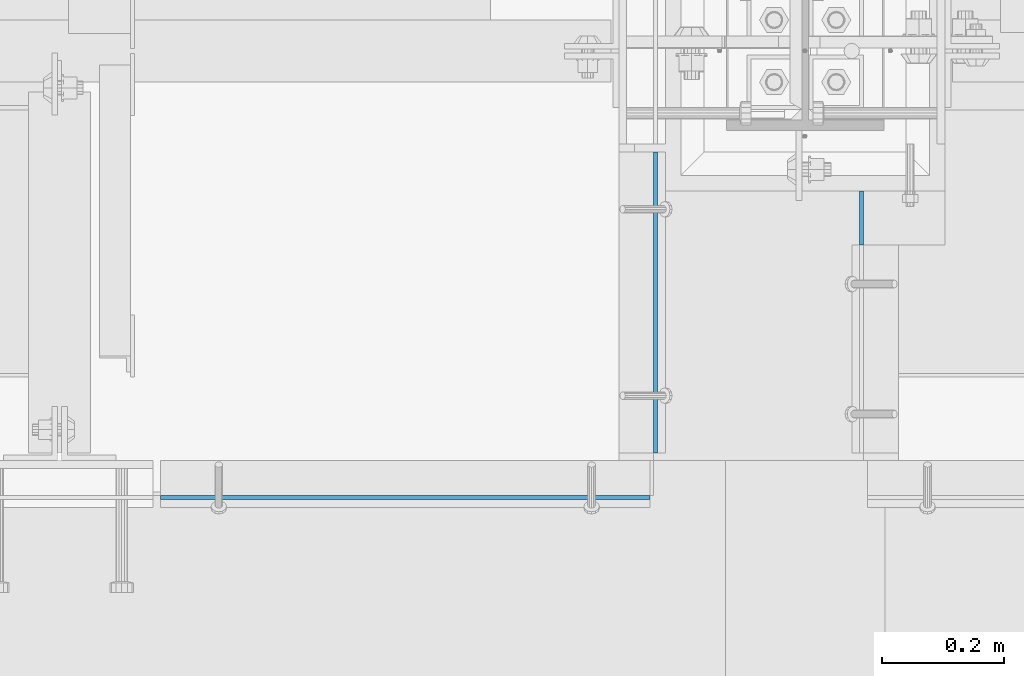
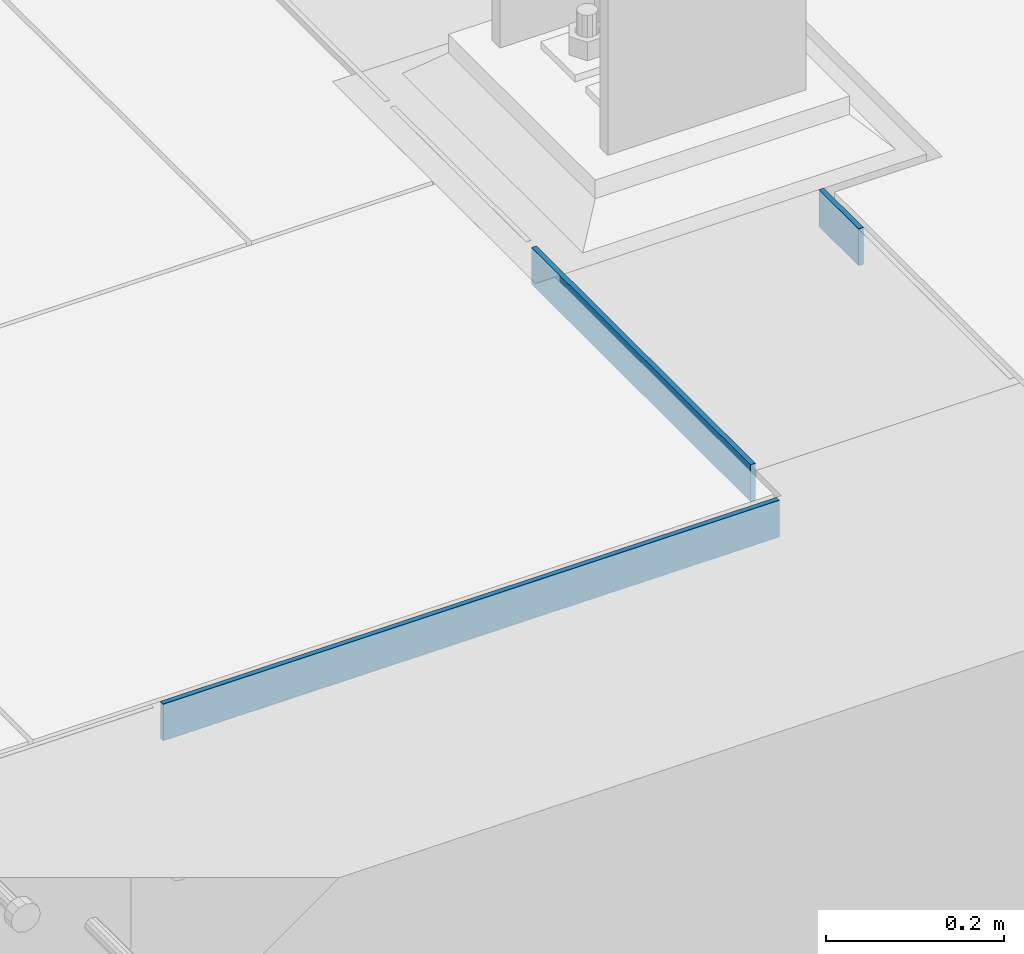
# One storey, part 3072 of 3843: 3 plates, 3 elements without a shape of their own.
"""IFC2X3 building model written with IfcOpenShell, lengths in millimetres."""

from ifc_helpers import new_model, si_unit, frame, origin_with_axes, place, context, subcontext, project, spatial, faceted_brep, material, type_object, element, aggregate, save


model = new_model("IFC2X3")

# Units and contexts
model_context = context("Model", 3, precision=1e-05, world=origin_with_axes())
body_context = subcontext(model_context, "Body", "Model", "MODEL_VIEW")
ifc_project = project(units=[si_unit("LENGTHUNIT", "METRE", prefix="MILLI"), si_unit("AREAUNIT", "SQUARE_METRE"), si_unit("VOLUMEUNIT", "CUBIC_METRE"), si_unit("MASSUNIT", "GRAM", prefix="KILO"), si_unit("TIMEUNIT", "SECOND"), si_unit("PLANEANGLEUNIT", "RADIAN"), si_unit("SOLIDANGLEUNIT", "STERADIAN"), si_unit("THERMODYNAMICTEMPERATUREUNIT", "DEGREE_CELSIUS"), si_unit("LUMINOUSINTENSITYUNIT", "LUMEN")], contexts=[model_context])

# Site, building, storey
site_placement = place(None, origin_with_axes())
site = spatial("IfcSite", under=ifc_project, at=site_placement, CompositionType="ELEMENT")
building_placement = place(site_placement, origin_with_axes())
building = spatial("IfcBuilding", under=site, at=building_placement, Name="Undefined", CompositionType="ELEMENT")
storey_placement = place(building_placement, origin_with_axes())
storey = spatial("IfcBuildingStorey", under=building, at=storey_placement, Name="Undefined", CompositionType="ELEMENT", Elevation=0.0)

# Assembly, plate
assembly_1_placement = place(storey_placement, origin_with_axes())
assembly_1 = element("IfcElementAssembly", 1, at=assembly_1_placement, inside=storey, Name="GRATING", AssemblyPlace="NOTDEFINED", PredefinedType="NOTDEFINED")
ifc_material = material(Name="STEEL/A36")
plate_type = type_object("IfcPlateType", PredefinedType="NOTDEFINED")
plate_1_placement = place(assembly_1_placement, frame((62728.475000002, 14681.1997676562, 30429.2000030518), z_axis=(0.0, 0.999999999997942, -2.02899998962774e-06), x_axis=(0.0, 2.02899999567308e-06, 0.999999999997942)))
plate_1 = element("IfcPlate", 2, at=plate_1_placement, type_object=plate_type, material=ifc_material, Name="PLATE", context=body_context, shape_type="Brep", body=[
    faceted_brep([(0.0, -3.17499999999927, 0.0), (0.000179417467734311, -3.17500000026484, 88.9001281746187), (0.000179417467734311, 3.17499999974098, 88.900128174615), (0.0, 3.17499999999927, 0.0), (50.8001812234725, -3.17500000026484, 88.9000671394897), (50.8001812234725, 3.17499999974098, 88.9000671394861), (50.7999954217848, -3.17499999999563, -7.27595761418343e-12), (50.7999954217848, 3.17500000001019, -1.09139364212751e-11)], [[[0, 1, 2, 3]], [[1, 4, 5, 2]], [[4, 6, 7, 5]], [[6, 0, 3, 7]], [[5, 7, 3, 2]], [[6, 4, 1, 0]]]),
])
aggregate(assembly_1, [plate_1])

assembly_2_placement = place(storey_placement, origin_with_axes())
assembly_2 = element("IfcElementAssembly", 3, at=assembly_2_placement, inside=storey, Name="ANGLE", AssemblyPlace="NOTDEFINED", PredefinedType="RIGID_FRAME")
plate_2_placement = place(assembly_2_placement, frame((62391.925002661, 14341.4750008351, 30429.2000030518), z_axis=(0.0, 0.999999999997942, -2.02899998962774e-06), x_axis=(0.0, 2.02899999567308e-06, 0.999999999997942)))
plate_2 = element("IfcPlate", 4, at=plate_2_placement, type_object=plate_type, material=ifc_material, Name="PLATE", context=body_context, shape_type="Brep", body=[
    faceted_brep([(0.0, -3.17499999999927, 0.0), (0.000990709220786812, -3.17500000288419, 492.1250000001), (0.000990709220786812, 3.17499999712163, 492.125000000102), (0.0, 3.17499999999927, 0.0), (50.8009872442017, -3.17500000288419, 492.124938964971), (50.8009872442017, 3.17499999712163, 492.124938964973), (50.7999954217848, -3.17499999999563, -7.27595761418343e-12), (50.7999954217848, 3.17500000001019, -1.09139364212751e-11)], [[[0, 1, 2, 3]], [[1, 4, 5, 2]], [[4, 6, 7, 5]], [[6, 0, 3, 7]], [[5, 7, 3, 2]], [[6, 4, 1, 0]]]),
])
aggregate(assembly_2, [plate_2])

assembly_3_placement = place(storey_placement, origin_with_axes())
assembly_3 = element("IfcElementAssembly", 5, at=assembly_3_placement, inside=storey, Name="ANGLE", AssemblyPlace="NOTDEFINED", PredefinedType="RIGID_FRAME")
plate_3_placement = place(assembly_3_placement, frame((61582.2999929627, 14268.4492432689, 30429.2000030518), z_axis=(1.0, 0.0, 0.0), x_axis=(0.0, 0.0, 1.0)))
plate_3 = element("IfcPlate", 6, at=plate_3_placement, type_object=plate_type, material=ifc_material, Name="PLATE", context=body_context, shape_type="Brep", body=[
    faceted_brep([(0.0, -3.17499999999927, 0.0), (-1.66381905728485e-05, -3.17500000000291, 800.100048828994), (-1.66381905728485e-05, 3.17499999999927, 800.100048828972), (0.0, 3.17499999999927, 0.0), (50.799981204138, -3.17500000000291, 800.100048829168), (50.799981204138, 3.17499999999927, 800.100048829139), (50.7999954217848, -3.17499999999563, -7.27595761418343e-12), (50.7999954217848, 3.17500000001019, -1.09139364212751e-11)], [[[0, 1, 2, 3]], [[1, 4, 5, 2]], [[4, 6, 7, 5]], [[6, 0, 3, 7]], [[5, 7, 3, 2]], [[6, 4, 1, 0]]]),
])
aggregate(assembly_3, [plate_3])

save(model, "model.ifc")
